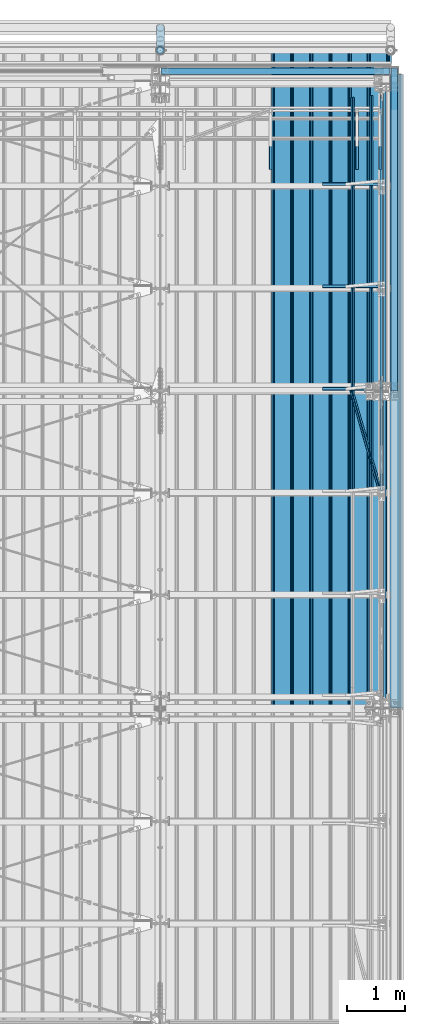
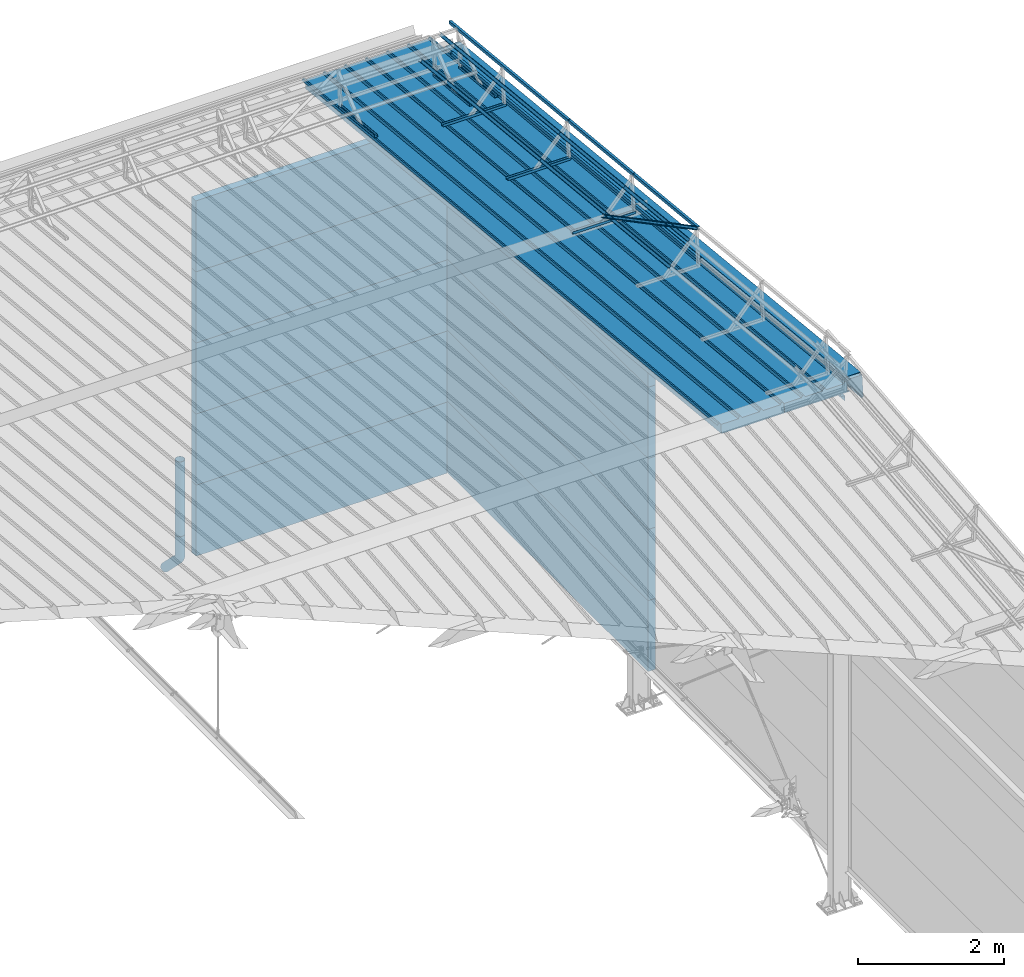
# One storey, part 80 of 709: 35 beams, 1 member, 36 elements without a shape of their own.
"""IFC4 building model written with IfcOpenShell, lengths in millimetres."""

from ifc_helpers import new_model, entity, si_unit, direction, frame, origin_with_axes, place, context, subcontext, project, spatial, line, indexed_curve, outline, extrude, material, element, aggregate, save


model = new_model("IFC4")

# Units and contexts
model_context = context("Model", 3, precision=0.2, world=origin_with_axes(), true_north=direction((0.0, 1.0)))
body_context = subcontext(model_context, "Body", "Model", "MODEL_VIEW")
ifc_project = project(units=[si_unit("LENGTHUNIT", "METRE", prefix="MILLI"), si_unit("AREAUNIT", "SQUARE_METRE"), si_unit("VOLUMEUNIT", "CUBIC_METRE"), si_unit("MASSUNIT", "GRAM", prefix="KILO"), si_unit("TIMEUNIT", "SECOND"), si_unit("PLANEANGLEUNIT", "RADIAN"), si_unit("SOLIDANGLEUNIT", "STERADIAN"), si_unit("THERMODYNAMICTEMPERATUREUNIT", "DEGREE_CELSIUS"), si_unit("LUMINOUSINTENSITYUNIT", "LUMEN")], contexts=[model_context])

# Site, building, storey
site_placement = place(None, origin_with_axes())
site = spatial("IfcSite", under=ifc_project, at=site_placement, CompositionType="ELEMENT")
building_placement = place(site_placement, origin_with_axes())
building = spatial("IfcBuilding", under=site, at=building_placement, Name="Undefined", CompositionType="ELEMENT")
storey_placement = place(building_placement, origin_with_axes())
storey = spatial("IfcBuildingStorey", under=building, at=storey_placement, Name="Undefined", CompositionType="ELEMENT", Elevation=0.0)

# Assembly, beam
assembly_1_placement = place(storey_placement, frame((49452.44, 11009.10459, 8419.96887), z_axis=(1.0, 0.0, 0.0), x_axis=(0.0, 0.9950371902, -0.099503719)))
assembly_1 = element("IfcElementAssembly", 1, at=assembly_1_placement, inside=storey)
ifc_material_1 = material(Name="Insulation", Category="Insulation")
beam_1_placement = place(assembly_1_placement, origin_with_axes())
beam_1 = element("IfcBeam", 2, at=beam_1_placement, material=ifc_material_1, ObjectType="P-99", context=body_context, shape_type="SolidModel", body=[
    extrude(outline(indexed_curve([(-509.8453, 89.5), (-490.1547, 89.5), (-471.67949, 57.5), (-471.67949, -88.5), (-436.67949, -88.5), (-436.67949, -91.5), (562.55841, -91.5), (562.55841, -89.5), (527.55841, -89.5), (527.55841, 57.5), (510.2379, 88.5), (489.7621, 88.5), (472.44159, 58.5), (196.71923, 58.5), (177.66667, 91.5), (155.66667, 91.5), (136.61411, 58.5), (-136.61411, 58.5), (-155.66667, 91.5), (-177.66667, 91.5), (-196.71923, 58.5), (-469.94744, 58.5), (-489.0, 91.5), (-511.0, 91.5), (-527.16581, 63.5), (-525.43376, 62.5)], segments=[line(1, 2, 3, 4, 5, 6, 7, 8, 9, 10, 11, 12, 13, 14, 15, 16, 17, 18, 19, 20, 21, 22, 23, 24, 25, 26, 1)])), frame((0.0, 0.0, 0.0), z_axis=(-1.0, 0.0, 0.0), x_axis=(0.0, 0.0, 1.0)), (0.0, 0.0, -1.0), 11459.0),
])
aggregate(assembly_1, [beam_1])

assembly_2_placement = place(storey_placement, frame((48452.44, 11009.10459, 8419.96887), z_axis=(1.0, 0.0, 0.0), x_axis=(0.0, 0.9950371902, -0.099503719)))
assembly_2 = element("IfcElementAssembly", 3, at=assembly_2_placement, inside=storey)
beam_2_placement = place(assembly_2_placement, origin_with_axes())
beam_2 = element("IfcBeam", 4, at=beam_2_placement, material=ifc_material_1, ObjectType="P-99", context=body_context, shape_type="SolidModel", body=[
    extrude(outline(indexed_curve([(-509.8453, 89.5), (-490.1547, 89.5), (-471.67949, 57.5), (-471.67949, -88.5), (-436.67949, -88.5), (-436.67949, -91.5), (562.55841, -91.5), (562.55841, -89.5), (527.55841, -89.5), (527.55841, 57.5), (510.2379, 88.5), (489.7621, 88.5), (472.44159, 58.5), (196.71923, 58.5), (177.66667, 91.5), (155.66667, 91.5), (136.61411, 58.5), (-136.61411, 58.5), (-155.66667, 91.5), (-177.66667, 91.5), (-196.71923, 58.5), (-469.94744, 58.5), (-489.0, 91.5), (-511.0, 91.5), (-527.16581, 63.5), (-525.43376, 62.5)], segments=[line(1, 2, 3, 4, 5, 6, 7, 8, 9, 10, 11, 12, 13, 14, 15, 16, 17, 18, 19, 20, 21, 22, 23, 24, 25, 26, 1)])), frame((0.0, 0.0, 0.0), z_axis=(-1.0, 0.0, 0.0), x_axis=(0.0, 0.0, 1.0)), (0.0, 0.0, -1.0), 11459.0),
])
aggregate(assembly_2, [beam_2])

assembly_3_placement = place(storey_placement, frame((49815.0, 21349.29926, 7565.33969), z_axis=(0.0, 0.099503719, 0.9950371902), x_axis=(0.0, -0.9950371902, 0.099503719)))
assembly_3 = element("IfcElementAssembly", 5, at=assembly_3_placement, inside=storey)
ifc_material_2 = material(Name="Steel_Undefined", Category="STEEL")
beam_3_placement = place(assembly_3_placement, origin_with_axes())
beam_3 = element("IfcBeam", 6, at=beam_3_placement, material=ifc_material_2, ObjectType="601", context=body_context, shape_type="SolidModel", body=[
    extrude(outline(indexed_curve([(-20.0, -25.0), (20.0, -25.0), (20.0, -22.5), (-17.5, -22.5), (-17.5, 22.5), (20.0, 22.5), (20.0, 25.0), (-20.0, 25.0)], segments=[line(1, 2, 3, 4, 5, 6, 7, 8, 1)])), frame((0.0, 0.0, 0.0), z_axis=(-1.0, 0.0, 0.0), x_axis=(0.0, 0.0, 1.0)), (0.0, 0.0, -1.0), 1000.0),
])
aggregate(assembly_3, [beam_3])

assembly_4_placement = place(storey_placement, frame((49415.0, 21349.29926, 7565.33969), z_axis=(0.0, 0.099503719, 0.9950371902), x_axis=(0.0, -0.9950371902, 0.099503719)))
assembly_4 = element("IfcElementAssembly", 7, at=assembly_4_placement, inside=storey)
beam_4_placement = place(assembly_4_placement, origin_with_axes())
beam_4 = element("IfcBeam", 8, at=beam_4_placement, material=ifc_material_2, ObjectType="601", context=body_context, shape_type="SolidModel", body=[
    extrude(outline(indexed_curve([(-20.0, -25.0), (20.0, -25.0), (20.0, -22.5), (-17.5, -22.5), (-17.5, 22.5), (20.0, 22.5), (20.0, 25.0), (-20.0, 25.0)], segments=[line(1, 2, 3, 4, 5, 6, 7, 8, 1)])), frame((0.0, 0.0, 0.0), z_axis=(-1.0, 0.0, 0.0), x_axis=(0.0, 0.0, 1.0)), (0.0, 0.0, -1.0), 1000.0),
])
aggregate(assembly_4, [beam_4])

assembly_5_placement = place(storey_placement, frame((47915.0, 21349.29926, 7565.33969), z_axis=(0.0, 0.099503719, 0.9950371902), x_axis=(0.0, -0.9950371902, 0.099503719)))
assembly_5 = element("IfcElementAssembly", 9, at=assembly_5_placement, inside=storey)
beam_5_placement = place(assembly_5_placement, origin_with_axes())
beam_5 = element("IfcBeam", 10, at=beam_5_placement, material=ifc_material_2, ObjectType="601", context=body_context, shape_type="SolidModel", body=[
    extrude(outline(indexed_curve([(-20.0, -25.0), (20.0, -25.0), (20.0, -22.5), (-17.5, -22.5), (-17.5, 22.5), (20.0, 22.5), (20.0, 25.0), (-20.0, 25.0)], segments=[line(1, 2, 3, 4, 5, 6, 7, 8, 1)])), frame((0.0, 0.0, 0.0), z_axis=(-1.0, 0.0, 0.0), x_axis=(0.0, 0.0, 1.0)), (0.0, 0.0, -1.0), 1000.0),
])
aggregate(assembly_5, [beam_5])

assembly_6_placement = place(storey_placement, frame((49815.0, 16546.76675, 8045.59294), z_axis=(0.0, 0.099503719, 0.9950371902), x_axis=(-1.0, 0.0, 0.0)))
assembly_6 = element("IfcElementAssembly", 11, at=assembly_6_placement, inside=storey)
beam_6_placement = place(assembly_6_placement, origin_with_axes())
beam_6 = element("IfcBeam", 12, at=beam_6_placement, material=ifc_material_2, ObjectType="601", context=body_context, shape_type="SolidModel", body=[
    extrude(outline(indexed_curve([(-20.0, -25.0), (20.0, -25.0), (20.0, -22.5), (-17.5, -22.5), (-17.5, 22.5), (20.0, 22.5), (20.0, 25.0), (-20.0, 25.0)], segments=[line(1, 2, 3, 4, 5, 6, 7, 8, 1)])), frame((0.0, 0.0, 0.0), z_axis=(-1.0, 0.0, 0.0), x_axis=(0.0, 0.0, 1.0)), (0.0, 0.0, -1.0), 1000.0),
])
aggregate(assembly_6, [beam_6])

assembly_7_placement = place(storey_placement, frame((49815.0, 18323.4665, 7867.92296), z_axis=(0.0, 0.099503719, 0.9950371902), x_axis=(-1.0, 0.0, 0.0)))
assembly_7 = element("IfcElementAssembly", 13, at=assembly_7_placement, inside=storey)
beam_7_placement = place(assembly_7_placement, origin_with_axes())
beam_7 = element("IfcBeam", 14, at=beam_7_placement, material=ifc_material_2, ObjectType="601", context=body_context, shape_type="SolidModel", body=[
    extrude(outline(indexed_curve([(-20.0, -25.0), (20.0, -25.0), (20.0, -22.5), (-17.5, -22.5), (-17.5, 22.5), (20.0, 22.5), (20.0, 25.0), (-20.0, 25.0)], segments=[line(1, 2, 3, 4, 5, 6, 7, 8, 1)])), frame((0.0, 0.0, 0.0), z_axis=(-1.0, 0.0, 0.0), x_axis=(0.0, 0.0, 1.0)), (0.0, 0.0, -1.0), 1000.0),
])
aggregate(assembly_7, [beam_7])

assembly_8_placement = place(storey_placement, frame((49815.0, 20100.16625, 7690.25299), z_axis=(0.0, 0.099503719, 0.9950371902), x_axis=(-1.0, 0.0, 0.0)))
assembly_8 = element("IfcElementAssembly", 15, at=assembly_8_placement, inside=storey)
beam_8_placement = place(assembly_8_placement, origin_with_axes())
beam_8 = element("IfcBeam", 16, at=beam_8_placement, material=ifc_material_2, ObjectType="601", context=body_context, shape_type="SolidModel", body=[
    extrude(outline(indexed_curve([(-20.0, -25.0), (20.0, -25.0), (20.0, -22.5), (-17.5, -22.5), (-17.5, 22.5), (20.0, 22.5), (20.0, 25.0), (-20.0, 25.0)], segments=[line(1, 2, 3, 4, 5, 6, 7, 8, 1)])), frame((0.0, 0.0, 0.0), z_axis=(-1.0, 0.0, 0.0), x_axis=(0.0, 0.0, 1.0)), (0.0, 0.0, -1.0), 1000.0),
])
aggregate(assembly_8, [beam_8])

assembly_9_placement = place(storey_placement, frame((49835.0, 14831.17866, 8800.04453), z_axis=(1.0, 0.0, 0.0), x_axis=(0.0, 0.9950371902, -0.099503719)))
assembly_9 = element("IfcElementAssembly", 17, at=assembly_9_placement, inside=storey)
beam_9_placement = place(assembly_9_placement, origin_with_axes())
beam_9 = element("IfcBeam", 18, at=beam_9_placement, material=ifc_material_2, ObjectType="610", context=body_context, shape_type="SolidModel", body=[
    extrude(outline(indexed_curve([(-20.0, -25.0), (20.0, -25.0), (20.0, -22.5), (-17.5, -22.5), (-17.5, 22.5), (20.0, 22.5), (20.0, 25.0), (-20.0, 25.0)], segments=[line(1, 2, 3, 4, 5, 6, 7, 8, 1)])), frame((0.0, 0.0, 0.0), z_axis=(-1.0, 0.0, 0.0), x_axis=(0.0, 0.0, 1.0)), (0.0, 0.0, -1.0), 1782.14469),
])
aggregate(assembly_9, [beam_9])

assembly_10_placement = place(storey_placement, frame((49835.0, 14781.4268, 8302.52594), z_axis=(1.0, 0.0, 0.0), x_axis=(0.0, 0.9950371902, -0.099503719)))
assembly_10 = element("IfcElementAssembly", 19, at=assembly_10_placement, inside=storey)
beam_10_placement = place(assembly_10_placement, origin_with_axes())
beam_10 = element("IfcBeam", 20, at=beam_10_placement, material=ifc_material_2, ObjectType="610", context=body_context, shape_type="SolidModel", body=[
    extrude(outline(indexed_curve([(-20.0, -25.0), (20.0, -25.0), (20.0, -22.5), (-17.5, -22.5), (-17.5, 22.5), (20.0, 22.5), (20.0, 25.0), (-20.0, 25.0)], segments=[line(1, 2, 3, 4, 5, 6, 7, 8, 1)])), frame((0.0, 0.0, 0.0), z_axis=(-1.0, 0.0, 0.0), x_axis=(0.0, 0.0, 1.0)), (0.0, 0.0, -1.0), 1782.14469),
])
aggregate(assembly_10, [beam_10])

assembly_11_placement = place(storey_placement, frame((49659.43651, 14818.5139, 8673.39698), z_axis=(-0.7071067814, 0.0703597545, 0.7035975445), x_axis=(0.0, 0.9950371902, -0.099503719)))
assembly_11 = element("IfcElementAssembly", 21, at=assembly_11_placement, inside=storey)
beam_11_placement = place(assembly_11_placement, origin_with_axes())
beam_11 = element("IfcBeam", 22, at=beam_11_placement, material=ifc_material_2, ObjectType="610", context=body_context, shape_type="SolidModel", body=[
    extrude(outline(indexed_curve([(-20.0, -25.0), (20.0, -25.0), (20.0, -22.5), (-17.5, -22.5), (-17.5, 22.5), (20.0, 22.5), (20.0, 25.0), (-20.0, 25.0)], segments=[line(1, 2, 3, 4, 5, 6, 7, 8, 1)])), frame((0.0, 0.0, 0.0), z_axis=(-1.0, 0.0, 0.0), x_axis=(0.0, 0.0, 1.0)), (0.0, 0.0, -1.0), 1782.14469),
])
aggregate(assembly_11, [beam_11])

assembly_12_placement = place(storey_placement, frame((49342.27922, 14786.95557, 8357.81368), z_axis=(-0.7071067814, 0.0703597545, 0.7035975445), x_axis=(0.0, 0.9950371902, -0.099503719)))
assembly_12 = element("IfcElementAssembly", 23, at=assembly_12_placement, inside=storey)
beam_12_placement = place(assembly_12_placement, origin_with_axes())
beam_12 = element("IfcBeam", 24, at=beam_12_placement, material=ifc_material_2, ObjectType="610", context=body_context, shape_type="SolidModel", body=[
    extrude(outline(indexed_curve([(-20.0, -25.0), (20.0, -25.0), (20.0, -22.5), (-17.5, -22.5), (-17.5, 22.5), (20.0, 22.5), (20.0, 25.0), (-20.0, 25.0)], segments=[line(1, 2, 3, 4, 5, 6, 7, 8, 1)])), frame((0.0, 0.0, 0.0), z_axis=(-1.0, 0.0, 0.0), x_axis=(0.0, 0.0, 1.0)), (0.0, 0.0, -1.0), 1782.14469),
])
aggregate(assembly_12, [beam_12])

assembly_13_placement = place(storey_placement, frame((49835.0, 16604.47891, 8622.71451), z_axis=(1.0, 0.0, 0.0), x_axis=(0.0, 0.9950371902, -0.099503719)))
assembly_13 = element("IfcElementAssembly", 25, at=assembly_13_placement, inside=storey)
beam_13_placement = place(assembly_13_placement, origin_with_axes())
beam_13 = element("IfcBeam", 26, at=beam_13_placement, material=ifc_material_2, ObjectType="609", context=body_context, shape_type="SolidModel", body=[
    extrude(outline(indexed_curve([(-20.0, -25.0), (20.0, -25.0), (20.0, -22.5), (-17.5, -22.5), (-17.5, 22.5), (20.0, 22.5), (20.0, 25.0), (-20.0, 25.0)], segments=[line(1, 2, 3, 4, 5, 6, 7, 8, 1)])), frame((0.0, 0.0, 0.0), z_axis=(-1.0, 0.0, 0.0), x_axis=(0.0, 0.0, 1.0)), (0.0, 0.0, -1.0), 1785.56115),
])
aggregate(assembly_13, [beam_13])

assembly_14_placement = place(storey_placement, frame((49835.0, 16554.72705, 8125.19591), z_axis=(1.0, 0.0, 0.0), x_axis=(0.0, 0.9950371902, -0.099503719)))
assembly_14 = element("IfcElementAssembly", 27, at=assembly_14_placement, inside=storey)
beam_14_placement = place(assembly_14_placement, origin_with_axes())
beam_14 = element("IfcBeam", 28, at=beam_14_placement, material=ifc_material_2, ObjectType="609", context=body_context, shape_type="SolidModel", body=[
    extrude(outline(indexed_curve([(-20.0, -25.0), (20.0, -25.0), (20.0, -22.5), (-17.5, -22.5), (-17.5, 22.5), (20.0, 22.5), (20.0, 25.0), (-20.0, 25.0)], segments=[line(1, 2, 3, 4, 5, 6, 7, 8, 1)])), frame((0.0, 0.0, 0.0), z_axis=(-1.0, 0.0, 0.0), x_axis=(0.0, 0.0, 1.0)), (0.0, 0.0, -1.0), 1785.56115),
])
aggregate(assembly_14, [beam_14])

assembly_15_placement = place(storey_placement, frame((49659.43651, 16591.81415, 8496.06695), z_axis=(-0.7071067814, 0.0703597545, 0.7035975445), x_axis=(0.0, 0.9950371902, -0.099503719)))
assembly_15 = element("IfcElementAssembly", 29, at=assembly_15_placement, inside=storey)
beam_15_placement = place(assembly_15_placement, origin_with_axes())
beam_15 = element("IfcBeam", 30, at=beam_15_placement, material=ifc_material_2, ObjectType="609", context=body_context, shape_type="SolidModel", body=[
    extrude(outline(indexed_curve([(-20.0, -25.0), (20.0, -25.0), (20.0, -22.5), (-17.5, -22.5), (-17.5, 22.5), (20.0, 22.5), (20.0, 25.0), (-20.0, 25.0)], segments=[line(1, 2, 3, 4, 5, 6, 7, 8, 1)])), frame((0.0, 0.0, 0.0), z_axis=(-1.0, 0.0, 0.0), x_axis=(0.0, 0.0, 1.0)), (0.0, 0.0, -1.0), 1785.56115),
])
aggregate(assembly_15, [beam_15])

assembly_16_placement = place(storey_placement, frame((49342.27922, 16560.25582, 8180.48365), z_axis=(-0.7071067814, 0.0703597545, 0.7035975445), x_axis=(0.0, 0.9950371902, -0.099503719)))
assembly_16 = element("IfcElementAssembly", 31, at=assembly_16_placement, inside=storey)
beam_16_placement = place(assembly_16_placement, origin_with_axes())
beam_16 = element("IfcBeam", 32, at=beam_16_placement, material=ifc_material_2, ObjectType="609", context=body_context, shape_type="SolidModel", body=[
    extrude(outline(indexed_curve([(-20.0, -25.0), (20.0, -25.0), (20.0, -22.5), (-17.5, -22.5), (-17.5, 22.5), (20.0, 22.5), (20.0, 25.0), (-20.0, 25.0)], segments=[line(1, 2, 3, 4, 5, 6, 7, 8, 1)])), frame((0.0, 0.0, 0.0), z_axis=(-1.0, 0.0, 0.0), x_axis=(0.0, 0.0, 1.0)), (0.0, 0.0, -1.0), 1785.56115),
])
aggregate(assembly_16, [beam_16])

assembly_17_placement = place(storey_placement, frame((49835.0, 18381.17866, 8445.04453), z_axis=(1.0, 0.0, 0.0), x_axis=(0.0, 0.9950371902, -0.099503719)))
assembly_17 = element("IfcElementAssembly", 33, at=assembly_17_placement, inside=storey)
beam_17_placement = place(assembly_17_placement, origin_with_axes())
beam_17 = element("IfcBeam", 34, at=beam_17_placement, material=ifc_material_2, ObjectType="608", context=body_context, shape_type="SolidModel", body=[
    extrude(outline(indexed_curve([(-20.0, -25.0), (20.0, -25.0), (20.0, -22.5), (-17.5, -22.5), (-17.5, 22.5), (20.0, 22.5), (20.0, 25.0), (-20.0, 25.0)], segments=[line(1, 2, 3, 4, 5, 6, 7, 8, 1)])), frame((0.0, 0.0, 0.0), z_axis=(-1.0, 0.0, 0.0), x_axis=(0.0, 0.0, 1.0)), (0.0, 0.0, -1.0), 3285.56115),
])
aggregate(assembly_17, [beam_17])

assembly_18_placement = place(storey_placement, frame((49835.0, 18331.4268, 7947.52594), z_axis=(1.0, 0.0, 0.0), x_axis=(0.0, 0.9950371902, -0.099503719)))
assembly_18 = element("IfcElementAssembly", 35, at=assembly_18_placement, inside=storey)
beam_18_placement = place(assembly_18_placement, origin_with_axes())
beam_18 = element("IfcBeam", 36, at=beam_18_placement, material=ifc_material_2, ObjectType="608", context=body_context, shape_type="SolidModel", body=[
    extrude(outline(indexed_curve([(-20.0, -25.0), (20.0, -25.0), (20.0, -22.5), (-17.5, -22.5), (-17.5, 22.5), (20.0, 22.5), (20.0, 25.0), (-20.0, 25.0)], segments=[line(1, 2, 3, 4, 5, 6, 7, 8, 1)])), frame((0.0, 0.0, 0.0), z_axis=(-1.0, 0.0, 0.0), x_axis=(0.0, 0.0, 1.0)), (0.0, 0.0, -1.0), 3285.56115),
])
aggregate(assembly_18, [beam_18])

assembly_19_placement = place(storey_placement, frame((49659.43651, 18368.5139, 8318.39698), z_axis=(-0.7071067814, 0.0703597545, 0.7035975445), x_axis=(0.0, 0.9950371902, -0.099503719)))
assembly_19 = element("IfcElementAssembly", 37, at=assembly_19_placement, inside=storey)
beam_19_placement = place(assembly_19_placement, origin_with_axes())
beam_19 = element("IfcBeam", 38, at=beam_19_placement, material=ifc_material_2, ObjectType="608", context=body_context, shape_type="SolidModel", body=[
    extrude(outline(indexed_curve([(-20.0, -25.0), (20.0, -25.0), (20.0, -22.5), (-17.5, -22.5), (-17.5, 22.5), (20.0, 22.5), (20.0, 25.0), (-20.0, 25.0)], segments=[line(1, 2, 3, 4, 5, 6, 7, 8, 1)])), frame((0.0, 0.0, 0.0), z_axis=(-1.0, 0.0, 0.0), x_axis=(0.0, 0.0, 1.0)), (0.0, 0.0, -1.0), 3285.56115),
])
aggregate(assembly_19, [beam_19])

assembly_20_placement = place(storey_placement, frame((49342.27922, 18336.95557, 8002.81368), z_axis=(-0.7071067814, 0.0703597545, 0.7035975445), x_axis=(0.0, 0.9950371902, -0.099503719)))
assembly_20 = element("IfcElementAssembly", 39, at=assembly_20_placement, inside=storey)
beam_20_placement = place(assembly_20_placement, origin_with_axes())
beam_20 = element("IfcBeam", 40, at=beam_20_placement, material=ifc_material_2, ObjectType="608", context=body_context, shape_type="SolidModel", body=[
    extrude(outline(indexed_curve([(-20.0, -25.0), (20.0, -25.0), (20.0, -22.5), (-17.5, -22.5), (-17.5, 22.5), (20.0, 22.5), (20.0, 25.0), (-20.0, 25.0)], segments=[line(1, 2, 3, 4, 5, 6, 7, 8, 1)])), frame((0.0, 0.0, 0.0), z_axis=(-1.0, 0.0, 0.0), x_axis=(0.0, 0.0, 1.0)), (0.0, 0.0, -1.0), 3285.56115),
])
aggregate(assembly_20, [beam_20])

# Assembly, member
assembly_21_placement = place(storey_placement, frame((49800.85786, 14832.58585, 8814.11648), z_axis=(-0.7071067814, 0.0703597545, 0.7035975445), x_axis=(-0.2585142331, 0.9004319084, -0.3498467802)))
assembly_21 = element("IfcElementAssembly", 41, at=assembly_21_placement, inside=storey)
member_placement = place(assembly_21_placement, origin_with_axes())
member = element("IfcMember", 42, at=member_placement, material=ifc_material_2, ObjectType="612", context=body_context, shape_type="SolidModel", body=[
    extrude(outline(indexed_curve([(-20.0, -25.0), (20.0, -25.0), (20.0, -22.5), (-17.5, -22.5), (-17.5, 22.5), (20.0, 22.5), (20.0, 25.0), (-20.0, 25.0)], segments=[line(1, 2, 3, 4, 5, 6, 7, 8, 1)])), frame((0.0, 0.0, 0.0), z_axis=(-1.0, 0.0, 0.0), x_axis=(0.0, 0.0, 1.0)), (0.0, 0.0, -1.0), 1914.6905),
])
aggregate(assembly_21, [member])

# Assembly, beam
assembly_22_placement = place(storey_placement, frame((46010.0, 22060.0, 895.0), z_axis=(0.0, 0.0, -1.0), x_axis=(1.0, 0.0, 0.0)))
assembly_22 = element("IfcElementAssembly", 43, at=assembly_22_placement, inside=storey)
beam_21_placement = place(assembly_22_placement, origin_with_axes())
beam_21 = element("IfcBeam", 44, at=beam_21_placement, material=ifc_material_1, ObjectType="P-118", context=body_context, shape_type="SolidModel", body=[
    extrude(outline(indexed_curve([(-595.0, -60.0), (595.0, -60.0), (595.0, 60.0), (-595.0, 60.0)], segments=[line(1, 2, 3, 4, 1)])), frame((0.0, 0.0, 0.0), z_axis=(-1.0, 0.0, 0.0), x_axis=(0.0, 0.0, 1.0)), (0.0, 0.0, -1.0), 3980.0),
])
aggregate(assembly_22, [beam_21])

assembly_23_placement = place(storey_placement, frame((46010.0, 22060.0, 2085.0), z_axis=(0.0, 0.0, -1.0), x_axis=(1.0, 0.0, 0.0)))
assembly_23 = element("IfcElementAssembly", 45, at=assembly_23_placement, inside=storey)
beam_22_placement = place(assembly_23_placement, origin_with_axes())
beam_22 = element("IfcBeam", 46, at=beam_22_placement, material=ifc_material_1, ObjectType="P-118", context=body_context, shape_type="SolidModel", body=[
    extrude(outline(indexed_curve([(-595.0, -60.0), (595.0, -60.0), (595.0, 60.0), (-595.0, 60.0)], segments=[line(1, 2, 3, 4, 1)])), frame((0.0, 0.0, 0.0), z_axis=(-1.0, 0.0, 0.0), x_axis=(0.0, 0.0, 1.0)), (0.0, 0.0, -1.0), 3980.0),
])
aggregate(assembly_23, [beam_22])

assembly_24_placement = place(storey_placement, frame((46010.0, 22060.0, 3275.0), z_axis=(0.0, 0.0, -1.0), x_axis=(1.0, 0.0, 0.0)))
assembly_24 = element("IfcElementAssembly", 47, at=assembly_24_placement, inside=storey)
beam_23_placement = place(assembly_24_placement, origin_with_axes())
beam_23 = element("IfcBeam", 48, at=beam_23_placement, material=ifc_material_1, ObjectType="P-118", context=body_context, shape_type="SolidModel", body=[
    extrude(outline(indexed_curve([(-595.0, -60.0), (595.0, -60.0), (595.0, 60.0), (-595.0, 60.0)], segments=[line(1, 2, 3, 4, 1)])), frame((0.0, 0.0, 0.0), z_axis=(-1.0, 0.0, 0.0), x_axis=(0.0, 0.0, 1.0)), (0.0, 0.0, -1.0), 3980.0),
])
aggregate(assembly_24, [beam_23])

assembly_25_placement = place(storey_placement, frame((46010.0, 22060.0, 4465.0), z_axis=(0.0, 0.0, -1.0), x_axis=(1.0, 0.0, 0.0)))
assembly_25 = element("IfcElementAssembly", 49, at=assembly_25_placement, inside=storey)
beam_24_placement = place(assembly_25_placement, origin_with_axes())
beam_24 = element("IfcBeam", 50, at=beam_24_placement, material=ifc_material_1, ObjectType="P-118", context=body_context, shape_type="SolidModel", body=[
    extrude(outline(indexed_curve([(-595.0, -60.0), (595.0, -60.0), (595.0, 60.0), (-595.0, 60.0)], segments=[line(1, 2, 3, 4, 1)])), frame((0.0, 0.0, 0.0), z_axis=(-1.0, 0.0, 0.0), x_axis=(0.0, 0.0, 1.0)), (0.0, 0.0, -1.0), 3980.0),
])
aggregate(assembly_25, [beam_24])

assembly_26_placement = place(storey_placement, frame((46010.0, 22060.0, 5655.0), z_axis=(0.0, 0.0, -1.0), x_axis=(1.0, 0.0, 0.0)))
assembly_26 = element("IfcElementAssembly", 51, at=assembly_26_placement, inside=storey)
beam_25_placement = place(assembly_26_placement, origin_with_axes())
beam_25 = element("IfcBeam", 52, at=beam_25_placement, material=ifc_material_1, ObjectType="P-118", context=body_context, shape_type="SolidModel", body=[
    extrude(outline(indexed_curve([(-595.0, -60.0), (595.0, -60.0), (595.0, 60.0), (-595.0, 60.0)], segments=[line(1, 2, 3, 4, 1)])), frame((0.0, 0.0, 0.0), z_axis=(-1.0, 0.0, 0.0), x_axis=(0.0, 0.0, 1.0)), (0.0, 0.0, -1.0), 3980.0),
])
aggregate(assembly_26, [beam_25])

assembly_27_placement = place(storey_placement, frame((46000.0, 22420.0, 1676.92297), z_axis=(0.0, -1.0, 0.0), x_axis=(0.0, 0.0, -1.0)))
assembly_27 = element("IfcElementAssembly", 53, at=assembly_27_placement, inside=storey)
beam_26_placement = place(assembly_27_placement, origin_with_axes())
beam_26 = element("IfcBeam", 54, at=beam_26_placement, material=ifc_material_2, ObjectType="614", context=body_context, shape_type="SolidModel", body=[
    extrude(outline(indexed_curve([(70.0, 0.0), (69.61653, 7.31699), (68.47033, 14.55382), (66.57396, 21.63119), (63.94818, 28.47157), (60.62178, 35.0), (56.63119, 41.14497), (52.02014, 46.83914), (46.83914, 52.02014), (41.14497, 56.63119), (35.0, 60.62178), (28.47157, 63.94818), (21.63119, 66.57396), (14.55382, 68.47033), (7.31699, 69.61653), (0.0, 70.0), (-7.31699, 69.61653), (-14.55382, 68.47033), (-21.63119, 66.57396), (-28.47157, 63.94818), (-35.0, 60.62178), (-41.14497, 56.63119), (-46.83914, 52.02014), (-52.02014, 46.83914), (-56.63119, 41.14497), (-60.62178, 35.0), (-63.94818, 28.47157), (-66.57396, 21.63119), (-68.47033, 14.55382), (-69.61653, 7.31699), (-70.0, 0.0), (-69.61653, -7.31699), (-68.47033, -14.55382), (-66.57396, -21.63119), (-63.94818, -28.47157), (-60.62178, -35.0), (-56.63119, -41.14497), (-52.02014, -46.83914), (-46.83914, -52.02014), (-41.14497, -56.63119), (-35.0, -60.62178), (-28.47157, -63.94818), (-21.63119, -66.57396), (-14.55382, -68.47033), (-7.31699, -69.61653), (0.0, -70.0), (7.31699, -69.61653), (14.55382, -68.47033), (21.63119, -66.57396), (28.47157, -63.94818), (35.0, -60.62178), (41.14497, -56.63119), (46.83914, -52.02014), (52.02014, -46.83914), (56.63119, -41.14497), (60.62178, -35.0), (63.94818, -28.47157), (66.57396, -21.63119), (68.47033, -14.55382), (69.61653, -7.31699)], segments=[line(1, 2, 3, 4, 5, 6, 7, 8, 9, 10, 11, 12, 13, 14, 15, 16, 17, 18, 19, 20, 21, 22, 23, 24, 25, 26, 27, 28, 29, 30, 31, 32, 33, 34, 35, 36, 37, 38, 39, 40, 41, 42, 43, 44, 45, 46, 47, 48, 49, 50, 51, 52, 53, 54, 55, 56, 57, 58, 59, 60, 1)]), holes=[indexed_curve([(65.0, 0.0), (64.64392, -6.79435), (63.57959, -13.51426), (61.81867, -20.0861), (59.38045, -26.43788), (56.29165, -32.5), (52.5861, -38.20604), (48.30441, -43.49349), (43.49349, -48.30441), (38.20604, -52.5861), (32.5, -56.29165), (26.43788, -59.38045), (20.0861, -61.81867), (13.51426, -63.57959), (6.79435, -64.64392), (0.0, -65.0), (-6.79435, -64.64392), (-13.51426, -63.57959), (-20.0861, -61.81867), (-26.43788, -59.38045), (-32.5, -56.29165), (-38.20604, -52.5861), (-43.49349, -48.30441), (-48.30441, -43.49349), (-52.5861, -38.20604), (-56.29165, -32.5), (-59.38045, -26.43788), (-61.81867, -20.0861), (-63.57959, -13.51426), (-64.64392, -6.79435), (-65.0, 0.0), (-64.64392, 6.79435), (-63.57959, 13.51426), (-61.81867, 20.0861), (-59.38045, 26.43788), (-56.29165, 32.5), (-52.5861, 38.20604), (-48.30441, 43.49349), (-43.49349, 48.30441), (-38.20604, 52.5861), (-32.5, 56.29165), (-26.43788, 59.38045), (-20.0861, 61.81867), (-13.51426, 63.57959), (-6.79435, 64.64392), (0.0, 65.0), (6.79435, 64.64392), (13.51426, 63.57959), (20.0861, 61.81867), (26.43788, 59.38045), (32.5, 56.29165), (38.20604, 52.5861), (43.49349, 48.30441), (48.30441, 43.49349), (52.5861, 38.20604), (56.29165, 32.5), (59.38045, 26.43788), (61.81867, 20.0861), (63.57959, 13.51426), (64.64392, 6.79435)], segments=[line(1, 2, 3, 4, 5, 6, 7, 8, 9, 10, 11, 12, 13, 14, 15, 16, 17, 18, 19, 20, 21, 22, 23, 24, 25, 26, 27, 28, 29, 30, 31, 32, 33, 34, 35, 36, 37, 38, 39, 40, 41, 42, 43, 44, 45, 46, 47, 48, 49, 50, 51, 52, 53, 54, 55, 56, 57, 58, 59, 60, 1)])]), frame((0.0, 0.0, 0.0), z_axis=(-1.0, 0.0, 0.0), x_axis=(0.0, 0.0, 1.0)), (0.0, 0.0, -1.0), 1250.0),
])
aggregate(assembly_27, [beam_26])

assembly_28_placement = place(storey_placement, frame((46000.0, 22420.0, 526.92297), z_axis=(1.0, 0.0, 0.0), x_axis=(0.0, 0.0, -1.0)))
assembly_28 = element("IfcElementAssembly", 55, at=assembly_28_placement, inside=storey)
beam_27_placement = place(assembly_28_placement, origin_with_axes())
beam_27 = element("IfcBeam", 56, at=beam_27_placement, material=ifc_material_2, ObjectType="617", context=body_context, shape_type="SolidModel", body=[
    entity("IfcSweptDiskSolid", entity("IfcIndexedPolyCurve", entity("IfcCartesianPointList3D", [[0.0, 0.0, 0.0], [448.2233, 0.0, 0.0], [496.05873, 9.51506, 0.0], [536.61165, 36.61165, 0.0], [900.0, 400.0, 0.0]]), [entity("IfcLineIndex", [1, 2]), entity("IfcArcIndex", [2, 3, 4]), entity("IfcLineIndex", [4, 5])]), 70.0, 65.0),
])
aggregate(assembly_28, [beam_27])

assembly_29_placement = place(storey_placement, frame((50060.0, 16510.0, 895.0), z_axis=(0.0, 0.0, -1.0), x_axis=(0.0, 1.0, 0.0)))
assembly_29 = element("IfcElementAssembly", 57, at=assembly_29_placement, inside=storey)
beam_28_placement = place(assembly_29_placement, origin_with_axes())
beam_28 = element("IfcBeam", 58, at=beam_28_placement, material=ifc_material_1, ObjectType="P-130", context=body_context, shape_type="SolidModel", body=[
    extrude(outline(indexed_curve([(-595.0, -60.0), (595.0, -60.0), (595.0, 60.0), (-595.0, 60.0)], segments=[line(1, 2, 3, 4, 1)])), frame((0.0, 0.0, 0.0), z_axis=(-1.0, 0.0, 0.0), x_axis=(0.0, 0.0, 1.0)), (0.0, 0.0, -1.0), 5610.0),
])
aggregate(assembly_29, [beam_28])

assembly_30_placement = place(storey_placement, frame((50060.0, 16510.0, 2085.0), z_axis=(0.0, 0.0, -1.0), x_axis=(0.0, 1.0, 0.0)))
assembly_30 = element("IfcElementAssembly", 59, at=assembly_30_placement, inside=storey)
beam_29_placement = place(assembly_30_placement, origin_with_axes())
beam_29 = element("IfcBeam", 60, at=beam_29_placement, material=ifc_material_1, ObjectType="P-130", context=body_context, shape_type="SolidModel", body=[
    extrude(outline(indexed_curve([(-595.0, -60.0), (595.0, -60.0), (595.0, 60.0), (-595.0, 60.0)], segments=[line(1, 2, 3, 4, 1)])), frame((0.0, 0.0, 0.0), z_axis=(-1.0, 0.0, 0.0), x_axis=(0.0, 0.0, 1.0)), (0.0, 0.0, -1.0), 5610.0),
])
aggregate(assembly_30, [beam_29])

assembly_31_placement = place(storey_placement, frame((50060.0, 16510.0, 3275.0), z_axis=(0.0, 0.0, -1.0), x_axis=(0.0, 1.0, 0.0)))
assembly_31 = element("IfcElementAssembly", 61, at=assembly_31_placement, inside=storey)
beam_30_placement = place(assembly_31_placement, origin_with_axes())
beam_30 = element("IfcBeam", 62, at=beam_30_placement, material=ifc_material_1, ObjectType="P-130", context=body_context, shape_type="SolidModel", body=[
    extrude(outline(indexed_curve([(-595.0, -60.0), (595.0, -60.0), (595.0, 60.0), (-595.0, 60.0)], segments=[line(1, 2, 3, 4, 1)])), frame((0.0, 0.0, 0.0), z_axis=(-1.0, 0.0, 0.0), x_axis=(0.0, 0.0, 1.0)), (0.0, 0.0, -1.0), 5610.0),
])
aggregate(assembly_31, [beam_30])

assembly_32_placement = place(storey_placement, frame((50060.0, 16510.0, 4465.0), z_axis=(0.0, 0.0, -1.0), x_axis=(0.0, 1.0, 0.0)))
assembly_32 = element("IfcElementAssembly", 63, at=assembly_32_placement, inside=storey)
beam_31_placement = place(assembly_32_placement, origin_with_axes())
beam_31 = element("IfcBeam", 64, at=beam_31_placement, material=ifc_material_1, ObjectType="P-130", context=body_context, shape_type="SolidModel", body=[
    extrude(outline(indexed_curve([(-595.0, -60.0), (595.0, -60.0), (595.0, 60.0), (-595.0, 60.0)], segments=[line(1, 2, 3, 4, 1)])), frame((0.0, 0.0, 0.0), z_axis=(-1.0, 0.0, 0.0), x_axis=(0.0, 0.0, 1.0)), (0.0, 0.0, -1.0), 5610.0),
])
aggregate(assembly_32, [beam_31])

assembly_33_placement = place(storey_placement, frame((50060.0, 16510.0, 5655.0), z_axis=(0.0, 0.0, -1.0), x_axis=(0.0, 1.0, 0.0)))
assembly_33 = element("IfcElementAssembly", 65, at=assembly_33_placement, inside=storey)
beam_32_placement = place(assembly_33_placement, origin_with_axes())
beam_32 = element("IfcBeam", 66, at=beam_32_placement, material=ifc_material_1, ObjectType="P-130", context=body_context, shape_type="SolidModel", body=[
    extrude(outline(indexed_curve([(-595.0, -60.0), (595.0, -60.0), (595.0, 60.0), (-595.0, 60.0)], segments=[line(1, 2, 3, 4, 1)])), frame((0.0, 0.0, 0.0), z_axis=(-1.0, 0.0, 0.0), x_axis=(0.0, 0.0, 1.0)), (0.0, 0.0, -1.0), 5610.0),
])
aggregate(assembly_33, [beam_32])

assembly_34_placement = place(storey_placement, frame((50110.0, 10984.6291, 8363.62532), z_axis=(0.0, 0.102472673, 0.9947358199), x_axis=(0.0, 0.9947358199, -0.102472673)))
assembly_34 = element("IfcElementAssembly", 67, at=assembly_34_placement, inside=storey)
beam_33_placement = place(assembly_34_placement, origin_with_axes())
beam_33 = element("IfcBeam", 68, at=beam_33_placement, material=ifc_material_2, context=body_context, shape_type="SolidModel", body=[
    extrude(outline(indexed_curve([(-175.0, -100.0), (175.0, -100.0), (175.0, 100.0), (160.75, 100.0), (160.75, 124.25), (159.13, 124.25), (159.13, 104.25), (159.88, 104.25), (159.88, 123.5), (160.0, 123.5), (160.0, 99.25), (174.25, 99.25), (174.25, -99.25), (-174.25, -99.25), (-174.25, -85.0), (-198.5, -85.0), (-198.5, -84.88), (-179.25, -84.88), (-179.25, -84.13), (-199.25, -84.13), (-199.25, -85.75), (-175.0, -85.75)], segments=[line(1, 2, 3, 4, 5, 6, 7, 8, 9, 10, 11, 12, 13, 14, 15, 16, 17, 18, 19, 20, 21, 22, 1)])), frame((0.0, 0.0, 0.0), z_axis=(-1.0, 0.0, 0.0), x_axis=(0.0, 0.0, 1.0)), (0.0, 0.0, -1.0), 11058.21242),
])
aggregate(assembly_34, [beam_33])

assembly_35_placement = place(storey_placement, frame((50080.0, 11007.68545, 8587.44088), z_axis=(-1.0, 0.0, 0.0), x_axis=(0.0, 0.9947358199, -0.102472673)))
assembly_35 = element("IfcElementAssembly", 69, at=assembly_35_placement, inside=storey)
beam_34_placement = place(assembly_35_placement, origin_with_axes())
beam_34 = element("IfcBeam", 70, at=beam_34_placement, material=ifc_material_2, context=body_context, shape_type="SolidModel", body=[
    extrude(outline(indexed_curve([(-110.0, -1.0), (110.0, -1.0), (131.2132, 20.2132), (129.79899, 21.62742), (109.17157, 1.0), (-108.0, 1.0), (-108.0, 49.0), (-110.0, 49.0)], segments=[line(1, 2, 3, 4, 5, 6, 7, 8, 1)])), frame((0.0, 0.0, 0.0), z_axis=(-1.0, 0.0, 0.0), x_axis=(0.0, 0.0, 1.0)), (0.0, 0.0, -1.0), 11058.21242),
])
aggregate(assembly_35, [beam_34])

assembly_36_placement = place(storey_placement, frame((49920.0, 10974.38183, 8264.15174), z_axis=(0.0, 0.102472673, 0.9947358199), x_axis=(0.0, 0.9947358199, -0.102472673)))
assembly_36 = element("IfcElementAssembly", 71, at=assembly_36_placement, inside=storey)
beam_35_placement = place(assembly_36_placement, origin_with_axes())
beam_35 = element("IfcBeam", 72, at=beam_35_placement, material=ifc_material_2, context=body_context, shape_type="SolidModel", body=[
    extrude(outline(indexed_curve([(-45.0, -1.0), (45.0, -1.0), (45.0, 49.0), (43.0, 49.0), (43.0, 1.0), (-45.0, 1.0)], segments=[line(1, 2, 3, 4, 5, 6, 1)])), frame((0.0, 0.0, 0.0), z_axis=(-1.0, 0.0, 0.0), x_axis=(0.0, 0.0, 1.0)), (0.0, 0.0, -1.0), 11058.21242),
])
aggregate(assembly_36, [beam_35])

save(model, "model.ifc")
